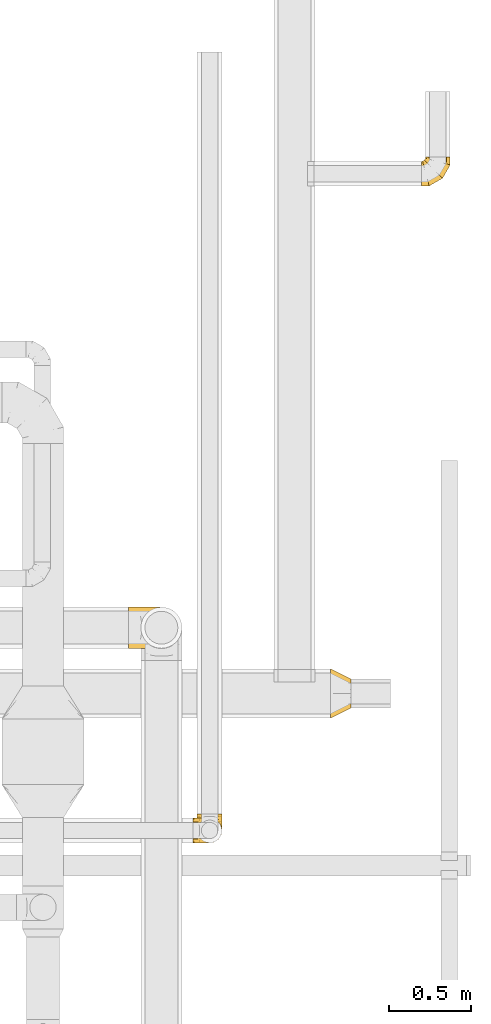
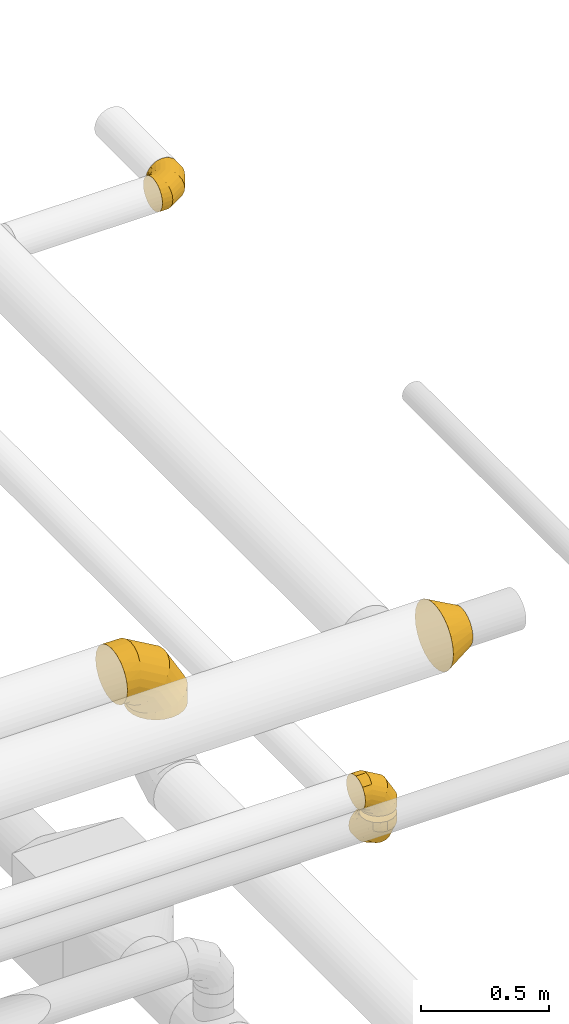
# One storey, part 28 of 92: 5 coverings.
"""IFC2X3 building model written with IfcOpenShell, lengths in millimetres."""

import ifcopenshell
import ifcopenshell.guid

model = None  # the IFC model being written
_history = None  # IfcOwnerHistory: only IFC2X3 demands one
_inside = {}  # id of a spatial element -> (the spatial element, [elements in it])
_under = {}  # id of a project, library or spatial element -> (it, [spatial elements below it])
_declared = {}  # id of a project -> (the project, [libraries it declares])
_typed = {}  # id of a type object -> (the type object, [elements of that type])
_made_of = {}  # id of a material, layer set ... -> (it, [elements and type objects made of it])


def new_model(schema):
    """Start an empty IFC model of exactly this schema.

    Asked for "IFC4X3", IfcOpenShell would pick the latest addendum, in which some entities
    have other attributes; the version numbers below select the first issue.
    IFC2X3 requires an IfcOwnerHistory on every rooted entity: one is made here for all.
    """
    global model, _history
    if schema == "IFC4X3":
        model = ifcopenshell.file(schema_version=(4, 3, 0, 0))
    else:
        model = ifcopenshell.file(schema=schema)
    _inside.clear()
    _under.clear()
    _declared.clear()
    _typed.clear()
    _made_of.clear()
    _history = None
    if model.schema == "IFC2X3":
        org = make("IfcOrganization", Name="unknown")
        user = make(
            "IfcPersonAndOrganization",
            ThePerson=make("IfcPerson", FamilyName="unknown"),
            TheOrganization=org,
        )
        app = make(
            "IfcApplication",
            ApplicationDeveloper=org,
            Version="unknown",
            ApplicationFullName="unknown",
            ApplicationIdentifier="unknown",
        )
        _history = make(
            "IfcOwnerHistory",
            OwningUser=user,
            OwningApplication=app,
            ChangeAction="ADDED",
            CreationDate=0,
        )
    return model


def make(cls, **values):
    """One entity of the class cls with the attributes given. An attribute that is None is left unset."""
    return model.create_entity(
        cls, **{name: value for name, value in values.items() if value is not None}
    )


def entity(cls, *values):
    """Any entity or typed value of the class cls, its attributes in the order of the schema. None: left unset."""
    e = model.create_entity(cls)
    for i, value in enumerate(values):
        if value is not None:
            e[i] = value
    return e


def rooted(cls, **values):
    """An entity with a GlobalId (a new one), such as an element, a storey or a relation."""
    return make(cls, GlobalId=ifcopenshell.guid.new(), OwnerHistory=_history, **values)


def si_unit(unit_type, name, prefix=None):
    """IfcSIUnit, for example si_unit("LENGTHUNIT", "METRE", prefix="MILLI")."""
    return make("IfcSIUnit", UnitType=unit_type, Prefix=prefix, Name=name)


def converted_unit(unit_type, name, factor, base, dimensions=None, offset=None):
    """IfcConversionBasedUnit, such as the inch: factor (a typed value) times the base unit."""
    return make(
        "IfcConversionBasedUnit"
        if offset is None
        else "IfcConversionBasedUnitWithOffset",
        ConversionOffset=offset,
        Dimensions=None
        if dimensions is None
        else entity("IfcDimensionalExponents", *dimensions),
        UnitType=unit_type,
        Name=name,
        ConversionFactor=make(
            "IfcMeasureWithUnit", ValueComponent=factor, UnitComponent=base
        ),
    )


def derived_unit(unit_type, elements):
    """IfcDerivedUnit: a product of units, each with its exponent."""
    return make(
        "IfcDerivedUnit",
        Elements=[
            make("IfcDerivedUnitElement", Unit=unit, Exponent=power)
            for unit, power in elements
        ],
        UnitType=unit_type,
    )


def assignment(units):
    """IfcUnitAssignment: the units of a project."""
    return None if units is None else make("IfcUnitAssignment", Units=units)


def point(xyz):
    """IfcCartesianPoint."""
    return None if xyz is None else make("IfcCartesianPoint", Coordinates=xyz)


def direction(xyz):
    """IfcDirection."""
    return None if xyz is None else make("IfcDirection", DirectionRatios=xyz)


def frame(location, z_axis=None, x_axis=None):
    """IfcAxis2Placement3D, a coordinate frame: its origin and axes. An axis left out is left unset."""
    return make(
        "IfcAxis2Placement3D",
        Location=point(location),
        Axis=direction(z_axis),
        RefDirection=direction(x_axis),
    )


def origin():
    """The frame at (0, 0, 0) with its axes left unset."""
    return frame((0.0, 0.0, 0.0))


def place(relative_to, where):
    """IfcLocalPlacement: puts the frame where relative to a parent placement (None: the world)."""
    return make(
        "IfcLocalPlacement", PlacementRelTo=relative_to, RelativePlacement=where
    )


def context(
    kind, dimensions, precision=None, world=None, true_north=None, identifier=None
):
    """IfcGeometricRepresentationContext, for example the 3D "Model" context."""
    return make(
        "IfcGeometricRepresentationContext",
        ContextIdentifier=identifier,
        ContextType=kind,
        CoordinateSpaceDimension=dimensions,
        Precision=precision,
        WorldCoordinateSystem=world,
        TrueNorth=true_north,
    )


def subcontext(parent, identifier, kind, view, scale=None):
    """IfcGeometricRepresentationSubContext, for example "Body" below "Model"."""
    return make(
        "IfcGeometricRepresentationSubContext",
        ContextIdentifier=identifier,
        ContextType=kind,
        ParentContext=parent,
        TargetScale=scale,
        TargetView=view,
    )


def project(units=None, contexts=None):
    """IfcProject with its units and contexts."""
    return rooted(
        "IfcProject",
        Name="project",
        RepresentationContexts=contexts,
        UnitsInContext=assignment(units),
    )


def spatial(cls, under=None, at=None, **own):
    """A site, building, storey or space (cls), placed at a placement, below another one or the project."""
    s = rooted(cls, ObjectPlacement=at, **own)
    if under is not None:
        _under.setdefault(under.id(), (under, []))[1].append(s)
    return s


def faces_of(points, faces, orient=None, outer=None):
    """IfcFace entities. A face is a list of loops; a loop is a list of indices into points, from 0.

    orient and outer hold one flag for each loop. By default every Orientation is true, the
    first loop of a face is its IfcFaceOuterBound and the others are IfcFaceBound.
    """
    made = []
    for i, loops in enumerate(faces):
        bounds = []
        for j, loop in enumerate(loops):
            is_outer = j == 0 if outer is None else outer[i][j]
            bounds.append(
                make(
                    "IfcFaceOuterBound" if is_outer else "IfcFaceBound",
                    Bound=make("IfcPolyLoop", Polygon=[points[k] for k in loop]),
                    Orientation=True if orient is None else orient[i][j],
                )
            )
        made.append(make("IfcFace", Bounds=bounds))
    return made


def faceted_brep(points, faces, orient=None, outer=None, voids=None):
    """IfcFacetedBrep: a solid bounded by flat faces; with voids (closed shells), ...WithVoids."""
    shared = [point(p) for p in points]
    hull = make("IfcClosedShell", CfsFaces=faces_of(shared, faces, orient, outer))
    if voids is None:
        return make("IfcFacetedBrep", Outer=hull)
    return make(
        "IfcFacetedBrepWithVoids",
        Outer=hull,
        Voids=[
            make(cls, CfsFaces=faces_of(shared, fs, o, b)) for cls, fs, o, b in voids
        ],
    )


def shape(context_of_items, identifier, shape_type, items):
    """IfcShapeRepresentation: the items that make up one representation, for example the "Body"."""
    return make(
        "IfcShapeRepresentation",
        ContextOfItems=context_of_items,
        RepresentationIdentifier=identifier,
        RepresentationType=shape_type,
        Items=items,
    )


def made_of(thing, what):
    """Note that an element or type object is made of a material, layer set ...; save() writes the relation."""
    if what is not None:
        _made_of.setdefault(what.id(), (what, []))[1].append(thing)
    return thing


def element(
    cls,
    number,
    at=None,
    inside=None,
    cuts=None,
    type_object=None,
    material=None,
    context=None,
    identifier="Body",
    shape_type=None,
    held_by="IfcProductDefinitionShape",
    body=None,
    shapes=None,
    **own,
):
    """One element of the class cls, such as IfcWall. Its Tag is "e" and its number.

    at: its placement. inside: the storey or other place that contains it. cuts: it is an
    opening in that element (IfcRelVoidsElement). A single representation is given by context,
    identifier, shape_type and body (its items); several are given by shapes. held_by: the class
    of the entity that holds the representations. save() writes the other relations.
    """
    e = rooted(cls, Tag="e%d" % number, ObjectPlacement=at, **own)
    if body is not None:
        shapes = [shape(context, identifier, shape_type, body)]
    if shapes is not None:
        e.Representation = make(held_by, Representations=shapes)
    if inside is not None:
        _inside.setdefault(inside.id(), (inside, []))[1].append(e)
    if cuts is not None:
        rooted(
            "IfcRelVoidsElement", RelatingBuildingElement=cuts, RelatedOpeningElement=e
        )
    if type_object is not None:
        _typed.setdefault(type_object.id(), (type_object, []))[1].append(e)
    return made_of(e, material)


def aggregate(whole, parts):
    """IfcRelAggregates: a whole, such as a stair, and the parts it consists of."""
    return rooted("IfcRelAggregates", RelatingObject=whole, RelatedObjects=parts)


def save(model, path):
    """Write the relations noted so far, then the file.

    IfcRelAggregates (storeys below a building ...), IfcRelContainedInSpatialStructure (elements
    in a storey), IfcRelDefinesByType, IfcRelAssociatesMaterial and IfcRelDeclares: one each for
    every whole, place, type object, material and project.
    """
    for whole, parts in _under.values():
        aggregate(whole, parts)
    for where, things in _inside.values():
        rooted(
            "IfcRelContainedInSpatialStructure",
            RelatedElements=things,
            RelatingStructure=where,
        )
    for kind, things in _typed.values():
        rooted("IfcRelDefinesByType", RelatedObjects=things, RelatingType=kind)
    for what, things in _made_of.values():
        rooted("IfcRelAssociatesMaterial", RelatedObjects=things, RelatingMaterial=what)
    for by, libraries in _declared.values():
        rooted("IfcRelDeclares", RelatingContext=by, RelatedDefinitions=libraries)
    model.write(path)


model = new_model("IFC2X3")

# Units and contexts
model_context = context("Model", 3, precision=0.01, world=origin(), true_north=direction((6.12303176911189e-17, 1.0)))
body_context = subcontext(model_context, "Body", "Model", "MODEL_VIEW")
ifc_project = project(units=[si_unit("LENGTHUNIT", "METRE", prefix="MILLI"), si_unit("AREAUNIT", "SQUARE_METRE"), si_unit("VOLUMEUNIT", "CUBIC_METRE"), converted_unit("PLANEANGLEUNIT", "DEGREE", entity("IfcRatioMeasure", 0.0174532925199433), si_unit("PLANEANGLEUNIT", "RADIAN"), dimensions=[0, 0, 0, 0, 0, 0, 0]), si_unit("MASSUNIT", "GRAM", prefix="KILO"), derived_unit("MASSDENSITYUNIT", [(si_unit("MASSUNIT", "GRAM", prefix="KILO"), 1), (si_unit("LENGTHUNIT", "METRE"), -3)]), derived_unit("MOMENTOFINERTIAUNIT", [(si_unit("LENGTHUNIT", "METRE"), 4)]), si_unit("TIMEUNIT", "SECOND"), si_unit("FREQUENCYUNIT", "HERTZ"), si_unit("THERMODYNAMICTEMPERATUREUNIT", "DEGREE_CELSIUS"), derived_unit("THERMALTRANSMITTANCEUNIT", [(si_unit("MASSUNIT", "GRAM", prefix="KILO"), 1), (si_unit("THERMODYNAMICTEMPERATUREUNIT", "KELVIN"), -1), (si_unit("TIMEUNIT", "SECOND"), -3)]), derived_unit("VOLUMETRICFLOWRATEUNIT", [(si_unit("LENGTHUNIT", "METRE"), 3), (si_unit("TIMEUNIT", "SECOND"), -1)]), derived_unit("MASSFLOWRATEUNIT", [(si_unit("MASSUNIT", "GRAM", prefix="KILO"), 1), (si_unit("TIMEUNIT", "SECOND"), -1)]), derived_unit("ROTATIONALFREQUENCYUNIT", [(si_unit("TIMEUNIT", "SECOND"), -1)]), si_unit("ELECTRICCURRENTUNIT", "AMPERE"), si_unit("ELECTRICVOLTAGEUNIT", "VOLT"), si_unit("POWERUNIT", "WATT"), si_unit("FORCEUNIT", "NEWTON", prefix="KILO"), si_unit("ILLUMINANCEUNIT", "LUX"), si_unit("LUMINOUSFLUXUNIT", "LUMEN"), si_unit("LUMINOUSINTENSITYUNIT", "CANDELA"), derived_unit("USERDEFINED", [(si_unit("MASSUNIT", "GRAM", prefix="KILO"), -1), (si_unit("LENGTHUNIT", "METRE"), -2), (si_unit("TIMEUNIT", "SECOND"), 3), (si_unit("LUMINOUSFLUXUNIT", "LUMEN"), 1)]), derived_unit("LINEARVELOCITYUNIT", [(si_unit("LENGTHUNIT", "METRE"), 1), (si_unit("TIMEUNIT", "SECOND"), -1)]), si_unit("PRESSUREUNIT", "PASCAL"), derived_unit("USERDEFINED", [(si_unit("LENGTHUNIT", "METRE"), -2), (si_unit("MASSUNIT", "GRAM", prefix="KILO"), 1), (si_unit("TIMEUNIT", "SECOND"), -2)]), derived_unit("LINEARFORCEUNIT", [(si_unit("MASSUNIT", "GRAM", prefix="KILO"), 1), (si_unit("LENGTHUNIT", "METRE"), 1), (si_unit("TIMEUNIT", "SECOND"), -2), (si_unit("LENGTHUNIT", "METRE"), -1)]), derived_unit("PLANARFORCEUNIT", [(si_unit("MASSUNIT", "GRAM", prefix="KILO"), 1), (si_unit("LENGTHUNIT", "METRE"), 1), (si_unit("TIMEUNIT", "SECOND"), -2), (si_unit("LENGTHUNIT", "METRE"), -2)])], contexts=[model_context])

# Site, building, storey
site_placement = place(None, origin())
site = spatial("IfcSite", under=ifc_project, at=site_placement, CompositionType="ELEMENT")
building_placement = place(site_placement, origin())
building = spatial("IfcBuilding", under=site, at=building_placement, CompositionType="ELEMENT")
storey_placement = place(building_placement, frame((0.0, 0.0, 4200.0)))
storey = spatial("IfcBuildingStorey", under=building, at=storey_placement, CompositionType="ELEMENT", Elevation=4200.0)

# Coverings
covering_1_placement = place(storey_placement, frame((70450.06, 9848.33, 3100.0)))
element("IfcCovering", 1, at=covering_1_placement, inside=storey, PredefinedType="INSULATION", context=body_context, shape_type="Brep", body=[
    faceted_brep([(0.0, 1.6, 200.0), (0.0, 7.71, 238.63), (0.0, 25.47, 273.47), (0.0, 53.12, 301.13), (0.0, 87.97, 318.88), (0.0, 126.6, 325.0), (0.0, 165.22, 318.88), (0.0, 200.07, 301.13), (0.0, 227.72, 273.47), (0.0, 245.48, 238.63), (0.0, 251.6, 200.0), (0.0, 245.48, 161.37), (0.0, 227.72, 126.53), (0.0, 200.07, 98.87), (0.0, 165.22, 81.12), (0.0, 126.6, 75.0), (0.0, 87.97, 81.12), (0.0, 53.12, 98.87), (0.0, 25.47, 126.53), (0.0, 7.71, 161.37), (308.25, 189.1, 0.0), (320.74, 158.95, 0.0), (325.0, 126.6, 0.0), (320.74, 94.24, 0.0), (308.25, 64.1, 0.0), (288.39, 38.21, 0.0), (262.5, 18.34, 0.0), (232.35, 5.85, 0.0), (200.0, 1.6, 0.0), (167.65, 5.85, 0.0), (137.5, 18.34, 0.0), (111.61, 38.21, 0.0), (91.75, 64.1, 0.0), (79.26, 94.24, 0.0), (75.0, 126.6, 0.0), (79.26, 158.95, 0.0), (91.75, 189.1, 0.0), (111.61, 214.98, 0.0), (137.5, 234.85, 0.0), (167.65, 247.34, 0.0), (200.0, 251.6, 0.0), (232.35, 247.34, 0.0), (262.5, 234.85, 0.0), (288.39, 214.98, 0.0), (325.0, 126.6, 87.08), (320.74, 94.24, 85.94), (308.25, 64.1, 82.6), (288.39, 38.21, 77.27), (262.5, 18.34, 70.34), (232.35, 5.85, 62.26), (200.0, 1.6, 53.59), (167.65, 5.85, 44.92), (137.5, 18.34, 36.84), (111.61, 38.21, 29.91), (91.75, 64.1, 24.58), (79.26, 94.24, 21.24), (75.0, 126.6, 20.1), (79.26, 158.95, 21.24), (91.75, 189.1, 24.58), (111.61, 214.98, 29.91), (167.65, 247.34, 44.92), (200.0, 251.6, 53.59), (137.5, 234.85, 36.84), (232.35, 247.34, 62.26), (262.5, 234.85, 70.34), (288.39, 214.98, 77.27), (308.25, 189.1, 82.6), (320.74, 158.95, 85.94), (237.92, 126.6, 237.92), (234.8, 94.24, 234.8), (225.66, 64.1, 225.66), (211.11, 38.21, 211.11), (192.16, 18.34, 192.16), (170.09, 5.85, 170.09), (146.41, 1.6, 146.41), (122.73, 5.85, 122.73), (100.66, 18.34, 100.66), (81.71, 38.21, 81.71), (67.16, 64.1, 67.16), (58.02, 94.24, 58.02), (54.9, 126.6, 54.9), (58.02, 158.95, 58.02), (67.16, 189.1, 67.16), (81.71, 214.98, 81.71), (122.73, 247.34, 122.73), (146.41, 251.6, 146.41), (100.66, 234.85, 100.66), (170.09, 247.34, 170.09), (192.16, 234.85, 192.16), (211.11, 214.98, 211.11), (225.66, 189.1, 225.66), (234.8, 158.95, 234.8), (87.08, 126.6, 325.0), (85.94, 94.24, 320.74), (82.6, 64.1, 308.25), (77.27, 38.21, 288.39), (70.34, 18.34, 262.5), (62.26, 5.85, 232.35), (53.59, 1.6, 200.0), (44.92, 5.85, 167.65), (36.84, 18.34, 137.5), (29.91, 38.21, 111.61), (24.58, 64.1, 91.75), (21.24, 94.24, 79.26), (20.1, 126.6, 75.0), (21.24, 158.95, 79.26), (24.58, 189.1, 91.75), (29.91, 214.98, 111.61), (44.92, 247.34, 167.65), (53.59, 251.6, 200.0), (36.84, 234.85, 137.5), (62.26, 247.34, 232.35), (70.34, 234.85, 262.5), (77.27, 214.98, 288.39), (82.6, 189.1, 308.25), (85.94, 158.95, 320.74)], [[[0, 1, 2, 3, 4, 5, 6, 7, 8, 9, 10, 11, 12, 13, 14, 15, 16, 17, 18, 19]], [[20, 21, 22, 23, 24, 25, 26, 27, 28, 29, 30, 31, 32, 33, 34, 35, 36, 37, 38, 39, 40, 41, 42, 43]], [[22, 44, 45, 23]], [[23, 45, 46, 24]], [[47, 25, 24, 46]], [[25, 47, 48, 26]], [[26, 48, 49, 27]], [[50, 28, 27, 49]], [[51, 52, 30, 29]], [[50, 51, 29, 28]], [[53, 31, 30, 52]], [[54, 55, 33, 32]], [[54, 32, 31, 53]], [[56, 34, 33, 55]], [[57, 58, 36, 35]], [[56, 57, 35, 34]], [[37, 36, 58, 59]], [[60, 61, 40, 39]], [[62, 60, 39, 38]], [[59, 62, 38, 37]], [[41, 40, 61, 63]], [[42, 41, 63, 64]], [[64, 65, 43, 42]], [[21, 20, 66, 67]], [[22, 21, 67, 44]], [[65, 66, 20, 43]], [[45, 44, 68, 69]], [[46, 45, 69, 70]], [[70, 71, 47, 46]], [[48, 47, 71, 72]], [[49, 48, 72, 73]], [[50, 49, 73, 74]], [[75, 76, 52, 51]], [[74, 75, 51, 50]], [[53, 52, 76, 77]], [[78, 79, 55, 54]], [[77, 78, 54, 53]], [[56, 55, 79, 80]], [[81, 82, 58, 57]], [[80, 81, 57, 56]], [[59, 58, 82, 83]], [[84, 85, 61, 60]], [[86, 84, 60, 62]], [[83, 86, 62, 59]], [[63, 61, 85, 87]], [[64, 63, 87, 88]], [[65, 64, 88, 89]], [[67, 66, 90, 91]], [[44, 67, 91, 68]], [[89, 90, 66, 65]], [[69, 68, 92, 93]], [[70, 69, 93, 94]], [[94, 95, 71, 70]], [[72, 71, 95, 96]], [[73, 72, 96, 97]], [[74, 73, 97, 98]], [[99, 100, 76, 75]], [[98, 99, 75, 74]], [[77, 76, 100, 101]], [[102, 103, 79, 78]], [[101, 102, 78, 77]], [[80, 79, 103, 104]], [[105, 106, 82, 81]], [[104, 105, 81, 80]], [[83, 82, 106, 107]], [[108, 109, 85, 84]], [[110, 108, 84, 86]], [[107, 110, 86, 83]], [[87, 85, 109, 111]], [[88, 87, 111, 112]], [[89, 88, 112, 113]], [[91, 90, 114, 115]], [[68, 91, 115, 92]], [[113, 114, 90, 89]], [[93, 5, 4]], [[94, 4, 3]], [[5, 93, 92]], [[93, 4, 94]], [[3, 95, 94]], [[96, 2, 1]], [[97, 1, 0]], [[95, 2, 96]], [[96, 1, 97]], [[0, 98, 97]], [[2, 95, 3]], [[99, 0, 19]], [[100, 19, 18]], [[99, 98, 0]], [[100, 99, 19]], [[18, 101, 100]], [[16, 15, 103]], [[17, 16, 102]], [[102, 101, 17]], [[104, 103, 15]], [[102, 16, 103]], [[17, 101, 18]], [[105, 15, 14]], [[106, 14, 13]], [[105, 104, 15]], [[106, 105, 14]], [[13, 107, 106]], [[110, 12, 11]], [[108, 11, 10]], [[110, 107, 12]], [[109, 108, 10]], [[110, 11, 108]], [[12, 107, 13]], [[111, 10, 9]], [[112, 9, 8]], [[10, 111, 109]], [[111, 9, 112]], [[8, 113, 112]], [[114, 7, 6]], [[115, 6, 5]], [[113, 7, 114]], [[115, 114, 6]], [[92, 115, 5]], [[7, 113, 8]]]),
])
covering_2_placement = place(storey_placement, frame((72230.0, 12657.45, 3223.4)))
element("IfcCovering", 2, at=covering_2_placement, inside=storey, PredefinedType="INSULATION", context=body_context, shape_type="Brep", body=[
    faceted_brep([(169.29, 176.6, 105.3), (172.15, 176.6, 90.95), (175.0, 176.6, 76.6), (172.15, 176.6, 62.24), (169.29, 176.6, 47.89), (161.16, 176.6, 35.73), (153.03, 176.6, 23.56), (140.87, 176.6, 15.43), (128.7, 176.6, 7.3), (114.35, 176.6, 4.45), (100.0, 176.6, 1.6), (85.65, 176.6, 4.45), (71.3, 176.6, 7.3), (59.13, 176.6, 15.43), (46.97, 176.6, 23.56), (38.84, 176.6, 35.73), (30.71, 176.6, 47.89), (27.85, 176.6, 62.24), (26.43, 176.6, 69.42), (25.0, 176.6, 76.6), (26.43, 176.6, 83.77), (27.85, 176.6, 90.95), (30.71, 176.6, 105.3), (38.84, 176.6, 117.46), (46.97, 176.6, 129.63), (59.13, 176.6, 137.76), (71.3, 176.6, 145.89), (85.65, 176.6, 148.74), (100.0, 176.6, 151.6), (114.35, 176.6, 148.74), (128.7, 176.6, 145.89), (140.87, 176.6, 137.76), (153.03, 176.6, 129.63), (161.16, 176.6, 117.46), (0.0, 4.15, 57.18), (0.0, 1.6, 76.6), (0.0, 4.15, 96.01), (0.0, 11.64, 114.1), (0.0, 23.56, 129.63), (0.0, 39.1, 141.55), (0.0, 57.18, 149.04), (0.0, 76.6, 151.6), (0.0, 96.01, 149.04), (0.0, 114.1, 141.55), (0.0, 129.63, 129.63), (0.0, 141.55, 114.1), (0.0, 149.04, 96.01), (0.0, 151.6, 76.6), (0.0, 149.04, 57.18), (0.0, 141.55, 39.1), (0.0, 129.63, 23.56), (0.0, 114.1, 11.64), (0.0, 96.01, 4.15), (0.0, 76.6, 1.6), (0.0, 57.18, 4.15), (0.0, 39.1, 11.64), (0.0, 23.56, 23.56), (0.0, 11.64, 39.1), (46.89, 1.6, 76.6), (46.21, 4.15, 96.01), (44.2, 11.64, 114.1), (41.01, 23.56, 129.63), (36.84, 39.1, 141.55), (32.0, 57.18, 149.04), (26.79, 76.6, 151.6), (21.59, 96.01, 149.04), (16.75, 114.1, 141.55), (12.58, 129.63, 129.63), (9.39, 141.55, 114.1), (7.38, 149.04, 96.01), (6.7, 151.6, 76.6), (7.38, 149.04, 57.18), (9.39, 141.55, 39.1), (12.58, 129.63, 23.56), (21.59, 96.01, 4.15), (26.79, 76.6, 1.6), (16.75, 114.1, 11.64), (32.0, 57.18, 4.15), (36.84, 39.1, 11.64), (41.01, 23.56, 23.56), (44.2, 11.64, 39.1), (46.21, 4.15, 57.18), (128.11, 48.49, 76.6), (126.24, 50.36, 96.01), (120.75, 55.84, 114.1), (112.03, 64.57, 129.63), (100.66, 75.94, 141.55), (87.42, 89.18, 149.04), (73.21, 103.39, 151.6), (58.99, 117.6, 149.04), (45.75, 130.84, 141.55), (34.38, 142.21, 129.63), (25.66, 150.94, 114.1), (20.17, 156.42, 96.01), (18.3, 158.29, 76.6), (20.17, 156.42, 57.18), (25.66, 150.94, 39.1), (34.38, 142.21, 23.56), (58.99, 117.6, 4.15), (73.21, 103.39, 1.6), (45.75, 130.84, 11.64), (87.42, 89.18, 4.15), (100.66, 75.94, 11.64), (112.03, 64.57, 23.56), (120.75, 55.84, 39.1), (126.24, 50.36, 57.18), (175.0, 129.7, 76.6), (172.44, 130.39, 96.01), (164.95, 132.4, 114.1), (153.03, 135.59, 129.63), (137.5, 139.75, 141.55), (119.41, 144.6, 149.04), (100.0, 149.8, 151.6), (80.59, 155.0, 149.04), (62.5, 159.85, 141.55), (46.97, 164.01, 129.63), (35.05, 167.2, 114.1), (31.3, 168.21, 105.05), (27.56, 169.21, 96.01), (26.28, 169.55, 86.3), (25.0, 169.9, 76.6), (27.56, 169.21, 57.18), (31.3, 168.21, 48.14), (35.05, 167.2, 39.1), (26.28, 169.55, 66.89), (46.97, 164.01, 23.56), (80.59, 155.0, 4.15), (100.0, 149.8, 1.6), (62.5, 159.85, 11.64), (119.41, 144.6, 4.15), (137.5, 139.75, 11.64), (153.03, 135.59, 23.56), (164.95, 132.4, 39.1), (172.44, 130.39, 57.18)], [[[0, 1, 2, 3, 4, 5, 6, 7, 8, 9, 10, 11, 12, 13, 14, 15, 16, 17, 18, 19, 20, 21, 22, 23, 24, 25, 26, 27, 28, 29, 30, 31, 32, 33]], [[34, 35, 36, 37, 38, 39, 40, 41, 42, 43, 44, 45, 46, 47, 48, 49, 50, 51, 52, 53, 54, 55, 56, 57]], [[35, 58, 59, 36]], [[36, 59, 60, 37]], [[37, 60, 61, 38]], [[39, 62, 63, 40]], [[40, 63, 64, 41]], [[38, 61, 62, 39]], [[65, 66, 43, 42]], [[64, 65, 42, 41]], [[67, 44, 43, 66]], [[68, 69, 46, 45]], [[68, 45, 44, 67]], [[70, 47, 46, 69]], [[71, 72, 49, 48]], [[70, 71, 48, 47]], [[50, 49, 72, 73]], [[74, 75, 53, 52]], [[76, 74, 52, 51]], [[73, 76, 51, 50]], [[55, 54, 77, 78]], [[56, 55, 78, 79]], [[53, 75, 77, 54]], [[34, 57, 80, 81]], [[35, 34, 81, 58]], [[79, 80, 57, 56]], [[58, 82, 83, 59]], [[60, 59, 83, 84]], [[84, 85, 61, 60]], [[62, 61, 85, 86]], [[63, 62, 86, 87]], [[64, 63, 87, 88]], [[89, 90, 66, 65]], [[88, 89, 65, 64]], [[67, 66, 90, 91]], [[92, 93, 69, 68]], [[91, 92, 68, 67]], [[70, 69, 93, 94]], [[95, 96, 72, 71]], [[94, 95, 71, 70]], [[73, 72, 96, 97]], [[98, 99, 75, 74]], [[100, 98, 74, 76]], [[97, 100, 76, 73]], [[77, 75, 99, 101]], [[78, 77, 101, 102]], [[79, 78, 102, 103]], [[81, 80, 104, 105]], [[58, 81, 105, 82]], [[103, 104, 80, 79]], [[82, 106, 107, 83]], [[84, 83, 107, 108]], [[108, 109, 85, 84]], [[86, 85, 109, 110]], [[87, 86, 110, 111]], [[88, 87, 111, 112]], [[113, 114, 90, 89]], [[112, 113, 89, 88]], [[91, 90, 114, 115]], [[93, 92, 116, 117, 118]], [[115, 116, 92, 91]], [[94, 93, 118, 119, 120]], [[95, 121, 122, 123, 96]], [[94, 120, 124, 121, 95]], [[97, 96, 123, 125]], [[126, 127, 99, 98]], [[128, 126, 98, 100]], [[125, 128, 100, 97]], [[101, 99, 127, 129]], [[102, 101, 129, 130]], [[103, 102, 130, 131]], [[105, 104, 132, 133]], [[82, 105, 133, 106]], [[131, 132, 104, 103]], [[106, 1, 107]], [[111, 30, 29]], [[1, 106, 2]], [[32, 109, 33]], [[108, 0, 33]], [[107, 0, 108]], [[31, 30, 110]], [[108, 33, 109]], [[31, 109, 32]], [[28, 112, 29]], [[1, 0, 107]], [[112, 111, 29]], [[110, 30, 111]], [[109, 31, 110]], [[113, 28, 27, 26]], [[24, 115, 25]], [[119, 21, 20]], [[114, 26, 25]], [[114, 113, 26]], [[120, 20, 19]], [[114, 25, 115]], [[28, 113, 112]], [[120, 119, 20]], [[21, 119, 118]], [[22, 118, 117, 116]], [[24, 23, 115]], [[115, 23, 116]], [[118, 22, 21]], [[116, 23, 22]], [[121, 17, 16]], [[15, 14, 125]], [[16, 123, 122, 121]], [[18, 17, 124]], [[18, 120, 19]], [[125, 123, 15]], [[13, 125, 14]], [[126, 12, 11, 10]], [[125, 13, 128]], [[120, 18, 124]], [[126, 128, 12]], [[126, 10, 127]], [[17, 121, 124]], [[123, 16, 15]], [[13, 12, 128]], [[127, 9, 129]], [[6, 131, 7]], [[130, 8, 7]], [[129, 8, 130]], [[5, 131, 6]], [[9, 8, 129]], [[130, 7, 131]], [[9, 127, 10]], [[133, 4, 3]], [[131, 5, 132]], [[2, 106, 3]], [[4, 133, 132]], [[106, 133, 3]], [[5, 4, 132]]]),
])
covering_3_placement = place(storey_placement, frame((71677.08, 9423.58, 3148.4)))
element("IfcCovering", 3, at=covering_3_placement, inside=storey, PredefinedType="INSULATION", context=body_context, shape_type="Brep", body=[
    faceted_brep([(0.0, 190.42, 296.48), (0.0, 226.6, 281.5), (0.0, 257.66, 257.66), (0.0, 281.5, 226.6), (0.0, 296.48, 190.42), (0.0, 301.6, 151.6), (0.0, 296.48, 112.77), (0.0, 281.5, 76.6), (0.0, 257.66, 45.53), (0.0, 226.6, 21.69), (0.0, 190.42, 6.71), (0.0, 151.6, 1.6), (0.0, 112.77, 6.71), (0.0, 76.6, 21.69), (0.0, 45.53, 45.53), (0.0, 21.69, 76.6), (0.0, 6.71, 112.77), (0.0, 1.6, 151.6), (0.0, 6.71, 190.42), (0.0, 21.69, 226.6), (0.0, 45.53, 257.66), (0.0, 76.6, 281.5), (0.0, 112.77, 296.48), (0.0, 151.6, 301.6), (125.0, 178.63, 234.81), (125.0, 151.6, 239.1), (125.0, 124.56, 234.81), (125.0, 100.16, 222.38), (125.0, 80.81, 203.03), (125.0, 68.38, 178.63), (125.0, 64.1, 151.6), (125.0, 68.38, 124.56), (125.0, 80.81, 100.16), (125.0, 100.16, 80.81), (125.0, 124.56, 68.38), (125.0, 151.6, 64.1), (125.0, 178.63, 68.38), (125.0, 203.03, 80.81), (125.0, 222.38, 100.16), (125.0, 234.81, 124.56), (125.0, 239.1, 151.6), (125.0, 234.81, 178.63), (125.0, 222.38, 203.03), (125.0, 203.03, 222.38)], [[[0, 1, 2, 3, 4, 5, 6, 7, 8, 9, 10, 11, 12, 13, 14, 15, 16, 17, 18, 19, 20, 21, 22, 23]], [[24, 25, 26, 27, 28, 29, 30, 31, 32, 33, 34, 35, 36, 37, 38, 39, 40, 41, 42, 43]], [[6, 40, 39]], [[7, 39, 38]], [[6, 5, 40]], [[7, 6, 39]], [[38, 8, 7]], [[36, 35, 10]], [[37, 36, 9]], [[8, 37, 9]], [[9, 36, 10]], [[35, 11, 10]], [[37, 8, 38]], [[12, 35, 34]], [[13, 34, 33]], [[12, 11, 35]], [[13, 12, 34]], [[33, 14, 13]], [[31, 30, 16]], [[32, 31, 15]], [[14, 32, 15]], [[15, 31, 16]], [[30, 17, 16]], [[32, 14, 33]], [[18, 30, 29]], [[19, 29, 28]], [[18, 17, 30]], [[19, 18, 29]], [[28, 20, 19]], [[26, 25, 22]], [[27, 26, 21]], [[20, 27, 21]], [[21, 26, 22]], [[25, 23, 22]], [[27, 20, 28]], [[0, 25, 24]], [[1, 24, 43]], [[0, 23, 25]], [[1, 0, 24]], [[43, 2, 1]], [[41, 40, 4]], [[42, 41, 3]], [[2, 42, 3]], [[3, 41, 4]], [[40, 5, 4]], [[42, 2, 43]]]),
])
covering_4_placement = place(storey_placement, frame((70865.99, 8666.09, 3043.4)))
element("IfcCovering", 4, at=covering_4_placement, inside=storey, PredefinedType="INSULATION", context=body_context, shape_type="Brep", body=[
    faceted_brep([(47.89, 7.3, 176.6), (62.24, 4.45, 176.6), (76.6, 1.6, 176.6), (90.95, 4.45, 176.6), (105.3, 7.3, 176.6), (117.46, 15.43, 176.6), (129.63, 23.56, 176.6), (137.76, 35.73, 176.6), (145.89, 47.89, 176.6), (148.74, 62.24, 176.6), (151.6, 76.6, 176.6), (148.74, 90.95, 176.6), (145.89, 105.3, 176.6), (137.76, 117.46, 176.6), (129.63, 129.63, 176.6), (117.46, 137.76, 176.6), (105.3, 145.89, 176.6), (90.95, 148.74, 176.6), (83.77, 150.17, 176.6), (76.6, 151.6, 176.6), (69.42, 150.17, 176.6), (62.24, 148.74, 176.6), (47.89, 145.89, 176.6), (35.73, 137.76, 176.6), (23.56, 129.63, 176.6), (15.43, 117.46, 176.6), (7.3, 105.3, 176.6), (4.45, 90.95, 176.6), (1.6, 76.6, 176.6), (4.45, 62.24, 176.6), (7.3, 47.89, 176.6), (15.43, 35.73, 176.6), (23.56, 23.56, 176.6), (35.73, 15.43, 176.6), (96.01, 176.6, 4.15), (76.6, 176.6, 1.6), (57.18, 176.6, 4.15), (39.1, 176.6, 11.64), (23.56, 176.6, 23.56), (11.64, 176.6, 39.1), (4.15, 176.6, 57.18), (1.6, 176.6, 76.6), (4.15, 176.6, 96.01), (11.64, 176.6, 114.1), (23.56, 176.6, 129.63), (39.1, 176.6, 141.55), (57.18, 176.6, 149.04), (76.6, 176.6, 151.6), (96.01, 176.6, 149.04), (114.1, 176.6, 141.55), (129.63, 176.6, 129.63), (141.55, 176.6, 114.1), (149.04, 176.6, 96.01), (151.6, 176.6, 76.6), (149.04, 176.6, 57.18), (141.55, 176.6, 39.1), (129.63, 176.6, 23.56), (114.1, 176.6, 11.64), (76.6, 129.7, 1.6), (57.18, 130.39, 4.15), (39.1, 132.4, 11.64), (23.56, 135.59, 23.56), (11.64, 139.75, 39.1), (4.15, 144.6, 57.18), (1.6, 149.8, 76.6), (4.15, 155.0, 96.01), (11.64, 159.85, 114.1), (23.56, 164.01, 129.63), (39.1, 167.2, 141.55), (57.18, 169.21, 149.04), (76.6, 169.9, 151.6), (96.01, 169.21, 149.04), (114.1, 167.2, 141.55), (129.63, 164.01, 129.63), (149.04, 155.0, 96.01), (151.6, 149.8, 76.6), (141.55, 159.85, 114.1), (149.04, 144.6, 57.18), (141.55, 139.75, 39.1), (129.63, 135.59, 23.56), (114.1, 132.4, 11.64), (96.01, 130.39, 4.15), (76.6, 48.49, 48.49), (57.18, 50.36, 50.36), (39.1, 55.84, 55.84), (23.56, 64.57, 64.57), (11.64, 75.94, 75.94), (4.15, 89.18, 89.18), (1.6, 103.39, 103.39), (4.15, 117.6, 117.6), (11.64, 130.84, 130.84), (23.56, 142.21, 142.21), (39.1, 150.94, 150.94), (57.18, 156.42, 156.42), (76.6, 158.29, 158.29), (96.01, 156.42, 156.42), (114.1, 150.94, 150.94), (129.63, 142.21, 142.21), (149.04, 117.6, 117.6), (151.6, 103.39, 103.39), (141.55, 130.84, 130.84), (149.04, 89.18, 89.18), (141.55, 75.94, 75.94), (129.63, 64.57, 64.57), (114.1, 55.84, 55.84), (96.01, 50.36, 50.36), (76.6, 1.6, 129.7), (57.18, 4.15, 130.39), (39.1, 11.64, 132.4), (23.56, 23.56, 135.59), (11.64, 39.1, 139.75), (4.15, 57.18, 144.6), (1.6, 76.6, 149.8), (4.15, 96.01, 155.0), (11.64, 114.1, 159.85), (23.56, 129.63, 164.01), (39.1, 141.55, 167.2), (48.14, 145.29, 168.21), (57.18, 149.04, 169.21), (66.89, 150.32, 169.55), (76.6, 151.6, 169.9), (96.01, 149.04, 169.21), (105.05, 145.29, 168.21), (114.1, 141.55, 167.2), (86.3, 150.32, 169.55), (129.63, 129.63, 164.01), (149.04, 96.01, 155.0), (151.6, 76.6, 149.8), (141.55, 114.1, 159.85), (149.04, 57.18, 144.6), (141.55, 39.1, 139.75), (129.63, 23.56, 135.59), (114.1, 11.64, 132.4), (96.01, 4.15, 130.39)], [[[0, 1, 2, 3, 4, 5, 6, 7, 8, 9, 10, 11, 12, 13, 14, 15, 16, 17, 18, 19, 20, 21, 22, 23, 24, 25, 26, 27, 28, 29, 30, 31, 32, 33]], [[34, 35, 36, 37, 38, 39, 40, 41, 42, 43, 44, 45, 46, 47, 48, 49, 50, 51, 52, 53, 54, 55, 56, 57]], [[35, 58, 59, 36]], [[36, 59, 60, 37]], [[37, 60, 61, 38]], [[39, 62, 63, 40]], [[40, 63, 64, 41]], [[38, 61, 62, 39]], [[65, 66, 43, 42]], [[64, 65, 42, 41]], [[67, 44, 43, 66]], [[68, 69, 46, 45]], [[68, 45, 44, 67]], [[70, 47, 46, 69]], [[71, 72, 49, 48]], [[70, 71, 48, 47]], [[50, 49, 72, 73]], [[74, 75, 53, 52]], [[76, 74, 52, 51]], [[73, 76, 51, 50]], [[55, 54, 77, 78]], [[56, 55, 78, 79]], [[53, 75, 77, 54]], [[34, 57, 80, 81]], [[35, 34, 81, 58]], [[79, 80, 57, 56]], [[58, 82, 83, 59]], [[60, 59, 83, 84]], [[84, 85, 61, 60]], [[62, 61, 85, 86]], [[63, 62, 86, 87]], [[64, 63, 87, 88]], [[89, 90, 66, 65]], [[88, 89, 65, 64]], [[67, 66, 90, 91]], [[92, 93, 69, 68]], [[91, 92, 68, 67]], [[70, 69, 93, 94]], [[95, 96, 72, 71]], [[94, 95, 71, 70]], [[73, 72, 96, 97]], [[98, 99, 75, 74]], [[100, 98, 74, 76]], [[97, 100, 76, 73]], [[77, 75, 99, 101]], [[78, 77, 101, 102]], [[79, 78, 102, 103]], [[81, 80, 104, 105]], [[58, 81, 105, 82]], [[103, 104, 80, 79]], [[82, 106, 107, 83]], [[84, 83, 107, 108]], [[108, 109, 85, 84]], [[86, 85, 109, 110]], [[87, 86, 110, 111]], [[88, 87, 111, 112]], [[113, 114, 90, 89]], [[112, 113, 89, 88]], [[91, 90, 114, 115]], [[93, 92, 116, 117, 118]], [[115, 116, 92, 91]], [[94, 93, 118, 119, 120]], [[95, 121, 122, 123, 96]], [[94, 120, 124, 121, 95]], [[97, 96, 123, 125]], [[126, 127, 99, 98]], [[128, 126, 98, 100]], [[125, 128, 100, 97]], [[101, 99, 127, 129]], [[102, 101, 129, 130]], [[103, 102, 130, 131]], [[105, 104, 132, 133]], [[82, 105, 133, 106]], [[131, 132, 104, 103]], [[106, 1, 107]], [[111, 30, 29]], [[1, 106, 2]], [[32, 109, 33]], [[108, 0, 33]], [[107, 0, 108]], [[31, 30, 110]], [[108, 33, 109]], [[31, 109, 32]], [[28, 112, 29]], [[1, 0, 107]], [[112, 111, 29]], [[110, 30, 111]], [[109, 31, 110]], [[113, 28, 27, 26]], [[24, 115, 25]], [[119, 21, 20]], [[114, 26, 25]], [[114, 113, 26]], [[120, 20, 19]], [[114, 25, 115]], [[28, 113, 112]], [[120, 119, 20]], [[21, 119, 118]], [[22, 118, 117, 116]], [[24, 23, 115]], [[115, 23, 116]], [[118, 22, 21]], [[116, 23, 22]], [[121, 17, 16]], [[15, 14, 125]], [[16, 123, 122, 121]], [[18, 17, 124]], [[18, 120, 19]], [[125, 123, 15]], [[13, 125, 14]], [[126, 12, 11, 10]], [[125, 13, 128]], [[120, 18, 124]], [[126, 128, 12]], [[126, 10, 127]], [[17, 121, 124]], [[123, 16, 15]], [[13, 12, 128]], [[127, 9, 129]], [[6, 131, 7]], [[130, 8, 7]], [[129, 8, 130]], [[5, 131, 6]], [[9, 8, 129]], [[130, 7, 131]], [[9, 127, 10]], [[133, 4, 3]], [[131, 5, 132]], [[2, 106, 3]], [[4, 133, 132]], [[106, 133, 3]], [[5, 4, 132]]]),
])
covering_5_placement = place(storey_placement, frame((70842.58, 8666.09, 3250.0)))
element("IfcCovering", 5, at=covering_5_placement, inside=storey, PredefinedType="INSULATION", context=body_context, shape_type="Brep", body=[
    faceted_brep([(0.0, 47.89, 169.29), (0.0, 62.24, 172.15), (0.0, 76.6, 175.0), (0.0, 90.95, 172.15), (0.0, 105.3, 169.29), (0.0, 117.46, 161.16), (0.0, 129.63, 153.03), (0.0, 137.76, 140.87), (0.0, 145.89, 128.7), (0.0, 148.74, 114.35), (0.0, 151.6, 100.0), (0.0, 148.74, 85.65), (0.0, 145.89, 71.3), (0.0, 137.76, 59.13), (0.0, 129.63, 46.97), (0.0, 117.46, 38.84), (0.0, 105.3, 30.71), (0.0, 90.95, 27.85), (0.0, 83.77, 26.43), (0.0, 76.6, 25.0), (0.0, 69.42, 26.43), (0.0, 62.24, 27.85), (0.0, 47.89, 30.71), (0.0, 35.73, 38.84), (0.0, 23.56, 46.97), (0.0, 15.43, 59.13), (0.0, 7.3, 71.3), (0.0, 4.45, 85.65), (0.0, 1.6, 100.0), (0.0, 4.45, 114.35), (0.0, 7.3, 128.7), (0.0, 15.43, 140.87), (0.0, 23.56, 153.03), (0.0, 35.73, 161.16), (172.44, 96.01, 0.0), (175.0, 76.6, 0.0), (172.44, 57.18, 0.0), (164.95, 39.1, 0.0), (153.03, 23.56, 0.0), (137.5, 11.64, 0.0), (119.41, 4.15, 0.0), (100.0, 1.6, 0.0), (80.59, 4.15, 0.0), (62.5, 11.64, 0.0), (46.97, 23.56, 0.0), (35.05, 39.1, 0.0), (27.56, 57.18, 0.0), (25.0, 76.6, 0.0), (27.56, 96.01, 0.0), (35.05, 114.1, 0.0), (46.97, 129.63, 0.0), (62.5, 141.55, 0.0), (80.59, 149.04, 0.0), (100.0, 151.6, 0.0), (119.41, 149.04, 0.0), (137.5, 141.55, 0.0), (153.03, 129.63, 0.0), (164.95, 114.1, 0.0), (175.0, 76.6, 46.89), (172.44, 57.18, 46.21), (164.95, 39.1, 44.2), (153.03, 23.56, 41.01), (137.5, 11.64, 36.84), (119.41, 4.15, 32.0), (100.0, 1.6, 26.79), (80.59, 4.15, 21.59), (62.5, 11.64, 16.75), (46.97, 23.56, 12.58), (35.05, 39.1, 9.39), (27.56, 57.18, 7.38), (25.0, 76.6, 6.7), (27.56, 96.01, 7.38), (35.05, 114.1, 9.39), (46.97, 129.63, 12.58), (80.59, 149.04, 21.59), (100.0, 151.6, 26.79), (62.5, 141.55, 16.75), (119.41, 149.04, 32.0), (137.5, 141.55, 36.84), (153.03, 129.63, 41.01), (164.95, 114.1, 44.2), (172.44, 96.01, 46.21), (128.11, 76.6, 128.11), (126.24, 57.18, 126.24), (120.75, 39.1, 120.75), (112.03, 23.56, 112.03), (100.66, 11.64, 100.66), (87.42, 4.15, 87.42), (73.21, 1.6, 73.21), (58.99, 4.15, 58.99), (45.75, 11.64, 45.75), (34.38, 23.56, 34.38), (25.66, 39.1, 25.66), (20.17, 57.18, 20.17), (18.3, 76.6, 18.3), (20.17, 96.01, 20.17), (25.66, 114.1, 25.66), (34.38, 129.63, 34.38), (58.99, 149.04, 58.99), (73.21, 151.6, 73.21), (45.75, 141.55, 45.75), (87.42, 149.04, 87.42), (100.66, 141.55, 100.66), (112.03, 129.63, 112.03), (120.75, 114.1, 120.75), (126.24, 96.01, 126.24), (46.89, 76.6, 175.0), (46.21, 57.18, 172.44), (44.2, 39.1, 164.95), (41.01, 23.56, 153.03), (36.84, 11.64, 137.5), (32.0, 4.15, 119.41), (26.79, 1.6, 100.0), (21.59, 4.15, 80.59), (16.75, 11.64, 62.5), (12.58, 23.56, 46.97), (9.39, 39.1, 35.05), (8.39, 48.14, 31.3), (7.38, 57.18, 27.56), (7.04, 66.89, 26.28), (6.7, 76.6, 25.0), (7.38, 96.01, 27.56), (8.39, 105.05, 31.3), (9.39, 114.1, 35.05), (7.04, 86.3, 26.28), (12.58, 129.63, 46.97), (21.59, 149.04, 80.59), (26.79, 151.6, 100.0), (16.75, 141.55, 62.5), (32.0, 149.04, 119.41), (36.84, 141.55, 137.5), (41.01, 129.63, 153.03), (44.2, 114.1, 164.95), (46.21, 96.01, 172.44)], [[[0, 1, 2, 3, 4, 5, 6, 7, 8, 9, 10, 11, 12, 13, 14, 15, 16, 17, 18, 19, 20, 21, 22, 23, 24, 25, 26, 27, 28, 29, 30, 31, 32, 33]], [[34, 35, 36, 37, 38, 39, 40, 41, 42, 43, 44, 45, 46, 47, 48, 49, 50, 51, 52, 53, 54, 55, 56, 57]], [[35, 58, 59, 36]], [[36, 59, 60, 37]], [[37, 60, 61, 38]], [[39, 62, 63, 40]], [[40, 63, 64, 41]], [[38, 61, 62, 39]], [[65, 66, 43, 42]], [[64, 65, 42, 41]], [[67, 44, 43, 66]], [[68, 69, 46, 45]], [[68, 45, 44, 67]], [[70, 47, 46, 69]], [[71, 72, 49, 48]], [[70, 71, 48, 47]], [[50, 49, 72, 73]], [[74, 75, 53, 52]], [[76, 74, 52, 51]], [[73, 76, 51, 50]], [[55, 54, 77, 78]], [[56, 55, 78, 79]], [[53, 75, 77, 54]], [[34, 57, 80, 81]], [[35, 34, 81, 58]], [[79, 80, 57, 56]], [[58, 82, 83, 59]], [[60, 59, 83, 84]], [[84, 85, 61, 60]], [[62, 61, 85, 86]], [[63, 62, 86, 87]], [[64, 63, 87, 88]], [[89, 90, 66, 65]], [[88, 89, 65, 64]], [[67, 66, 90, 91]], [[92, 93, 69, 68]], [[91, 92, 68, 67]], [[70, 69, 93, 94]], [[95, 96, 72, 71]], [[94, 95, 71, 70]], [[73, 72, 96, 97]], [[98, 99, 75, 74]], [[100, 98, 74, 76]], [[97, 100, 76, 73]], [[77, 75, 99, 101]], [[78, 77, 101, 102]], [[79, 78, 102, 103]], [[81, 80, 104, 105]], [[58, 81, 105, 82]], [[103, 104, 80, 79]], [[82, 106, 107, 83]], [[84, 83, 107, 108]], [[108, 109, 85, 84]], [[86, 85, 109, 110]], [[87, 86, 110, 111]], [[88, 87, 111, 112]], [[113, 114, 90, 89]], [[112, 113, 89, 88]], [[91, 90, 114, 115]], [[93, 92, 116, 117, 118]], [[115, 116, 92, 91]], [[94, 93, 118, 119, 120]], [[95, 121, 122, 123, 96]], [[94, 120, 124, 121, 95]], [[97, 96, 123, 125]], [[126, 127, 99, 98]], [[128, 126, 98, 100]], [[125, 128, 100, 97]], [[101, 99, 127, 129]], [[102, 101, 129, 130]], [[103, 102, 130, 131]], [[105, 104, 132, 133]], [[82, 105, 133, 106]], [[131, 132, 104, 103]], [[106, 1, 107]], [[111, 30, 29]], [[1, 106, 2]], [[32, 109, 33]], [[108, 0, 33]], [[107, 0, 108]], [[31, 30, 110]], [[108, 33, 109]], [[31, 109, 32]], [[28, 112, 29]], [[1, 0, 107]], [[112, 111, 29]], [[110, 30, 111]], [[109, 31, 110]], [[113, 28, 27, 26]], [[24, 115, 25]], [[119, 21, 20]], [[114, 26, 25]], [[114, 113, 26]], [[120, 20, 19]], [[114, 25, 115]], [[28, 113, 112]], [[120, 119, 20]], [[21, 119, 118]], [[22, 118, 117, 116]], [[24, 23, 115]], [[115, 23, 116]], [[118, 22, 21]], [[116, 23, 22]], [[121, 17, 16]], [[15, 14, 125]], [[16, 123, 122, 121]], [[18, 17, 124]], [[18, 120, 19]], [[125, 123, 15]], [[13, 125, 14]], [[126, 12, 11, 10]], [[125, 13, 128]], [[120, 18, 124]], [[126, 128, 12]], [[126, 10, 127]], [[17, 121, 124]], [[123, 16, 15]], [[13, 12, 128]], [[127, 9, 129]], [[6, 131, 7]], [[130, 8, 7]], [[129, 8, 130]], [[5, 131, 6]], [[9, 8, 129]], [[130, 7, 131]], [[9, 127, 10]], [[133, 4, 3]], [[131, 5, 132]], [[2, 106, 3]], [[4, 133, 132]], [[106, 133, 3]], [[5, 4, 132]]]),
])

save(model, "model.ifc")
